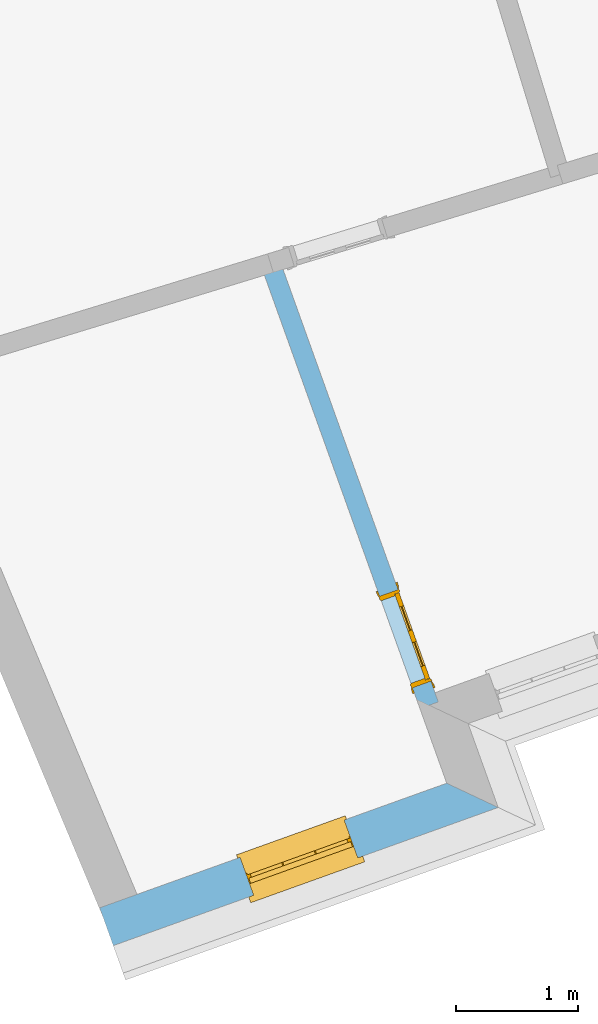
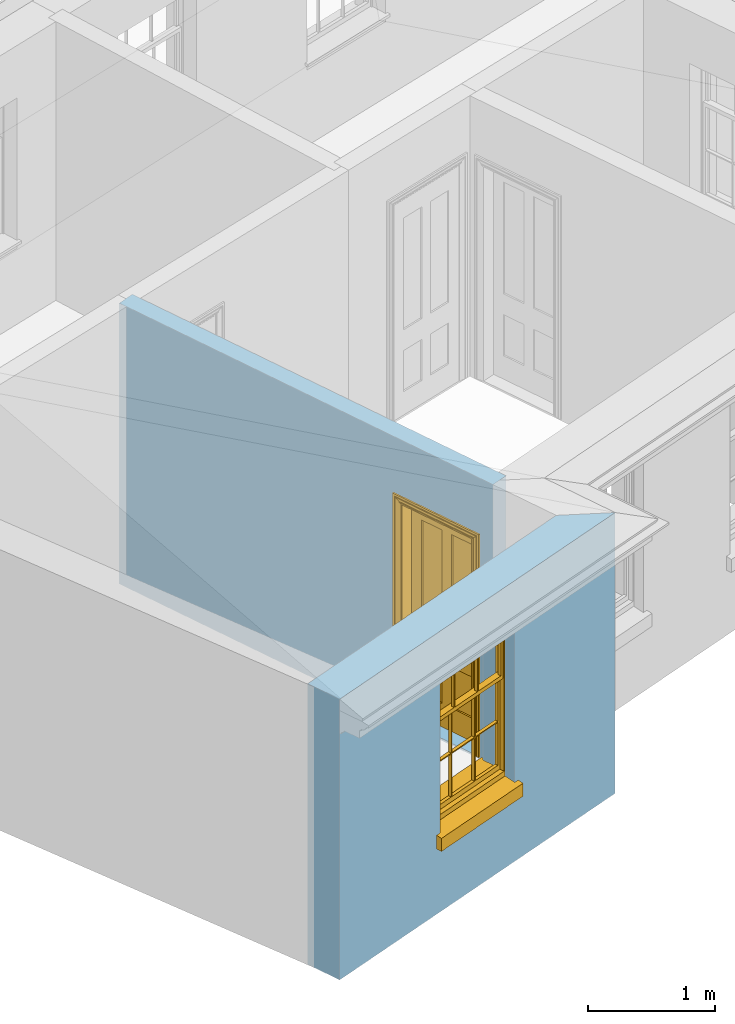
# One storey, part 2 of 10: 1 door, 1 window, 2 openings, plus 2 elements that do not belong to this part.
"""IFC2X3 building model written with IfcOpenShell, lengths in metres."""

from ifc_helpers import new_model, si_unit, frame, origin, place, context, subcontext, project, spatial, polyline, outline, extrude, faceted_brep, material, layer, layer_set, layer_usage, element, fill, save


model = new_model("IFC2X3")

# Units and contexts
model_context = context("Model", 3, world=origin())
body_context = subcontext(model_context, "Body", "Model", "MODEL_VIEW")
ifc_project = project(units=[si_unit("PLANEANGLEUNIT", "RADIAN"), si_unit("MASSUNIT", "GRAM", prefix="KILO"), si_unit("FORCEUNIT", "NEWTON", prefix="KILO"), si_unit("LENGTHUNIT", "METRE")], contexts=[model_context])

# Site, building, storey
site_placement = place(None, origin())
site = spatial("IfcSite", under=ifc_project, at=site_placement, CompositionType="ELEMENT")
building_placement = place(None, origin())
building = spatial("IfcBuilding", under=site, at=building_placement, Name="Building plot-9", CompositionType="ELEMENT")
storey_placement = place(None, frame((0.0, 0.0, 4.3)))
storey = spatial("IfcBuildingStorey", under=building, at=storey_placement, Name="Floor 1", CompositionType="ELEMENT", Elevation=4.3)

# Wall, opening, window
ifc_material_1 = material(Name="Masonry")
ifc_layer_1 = layer(ifc_material_1, 0.33, ventilated=False)
ifc_layer_set_1 = layer_set([ifc_layer_1], Name="My Wall")
ifc_layer_usage_1 = layer_usage(ifc_layer_set_1, "AXIS2", "NEGATIVE", 0.08)
wall_1_placement = place(storey_placement, origin())
wall_1 = element("IfcWallStandardCase", 1, at=wall_1_placement, inside=storey, material=ifc_layer_usage_1, Name="exterior", context=body_context, shape_type="SweptSolid", body=[
    extrude(outline(polyline([(31.1651656744123, 12.8391071130311), (31.2766588517913, 12.5285120850639), (34.4384860645198, 13.6635018000555), (34.0163978591737, 13.8626036506437), (31.1651656744123, 12.8391071130311)])), origin(), (0.0, 0.0, 1.0), 2.7),
])
opening_1_placement = place(storey_placement, frame((0.0, 0.0, 0.75)))
opening_1 = element("IfcOpeningElement", 2, at=opening_1_placement, cuts=wall_1, Name="Opening", ObjectType="Opening", context=body_context, shape_type="SweptSolid", body=[
    extrude(outline(polyline([(32.4293277983826, 12.9422815010221), (33.2858171179285, 13.2497323840973), (33.1743239405496, 13.5603274120645), (32.3178346210036, 13.2528765289893), (32.4293277983826, 12.9422815010221)])), origin(), (0.0, 0.0, 1.0), 1.445),
])
window_placement = place(storey_placement, frame((32.3448632700652, 13.1775807646336, 0.75), z_axis=(0.0, 0.0, 1.0), x_axis=(0.856489319545936, 0.30745088307525, 0.0)))
window = element("IfcWindow", 3, at=window_placement, inside=storey, Name="bedroom outside window", OverallHeight=1.445, OverallWidth=0.91, context=body_context, shape_type="Brep", held_by="IfcProductRepresentation", body=[
    faceted_brep([(0.876875, -0.105, 0.999097), (0.876875, -0.105, 1.411875), (0.9, -0.105, 1.435), (0.033125, -0.105, 1.411875), (0.033125, -0.105, 0.999097), (0.01, -0.105, 1.435), (0.033125, -0.135, 1.411875), (0.01, -0.135, 1.435), (0.033125, -0.135, 0.999097), (0.876875, -0.135, 1.411875), (0.876875, -0.135, 0.999097), (0.9, -0.135, 1.435), (0.033125, -0.105, 0.960972), (0.01, -0.105, 0.960972), (0.033125, -0.105, 0.548195), (0.876875, -0.105, 0.960972), (0.876875, -0.105, 0.548195), (0.9, -0.105, 0.960972), (0.876875, -0.105, 0.538195), (0.876875, -0.105, 0.125417), (0.9, -0.105, 0.077167), (0.033125, -0.105, 0.125417), (0.033125, -0.105, 0.538195), (0.01, -0.105, 0.077167), (0.9, -0.135, 0.960972), (0.01, -0.135, 0.960972), (-0.0425, -0.25, 0.01), (-0.0425, -0.3, 0.001667), (0.0, -0.25, 0.01), (0.9525, -0.25, 0.01), (0.91, -0.25, 0.01), (0.9525, -0.3, 0.001667), (-0.02, 0.08, 0.077167), (0.0, 0.08, 0.077167), (-0.02, 0.11, 0.077167), (0.0, -0.06, 0.077167), (0.01, -0.06, 0.077167), (0.91, -0.06, 0.077167), (0.91, 0.08, 0.077167), (0.9, -0.06, 0.077167), (0.93, 0.08, 0.077167), (0.93, 0.11, 0.077167), (0.01, -0.105, 0.999097), (0.01, -0.075, 0.999097), (0.9, -0.105, 0.999097), (0.9, -0.075, 0.999097), (0.876875, -0.075, 0.125417), (0.876875, -0.075, 0.538195), (0.9, -0.075, 0.077167), (0.876875, -0.075, 0.548195), (0.876875, -0.075, 0.960972), (0.033125, -0.075, 0.125417), (0.01, -0.075, 0.077167), (0.033125, -0.075, 0.538195), (0.033125, -0.075, 0.960972), (0.033125, -0.075, 0.548195), (-0.02, 0.08, 0.052167), (-0.02, 0.11, 0.052167), (0.93, 0.11, 0.052167), (0.93, 0.08, 0.052167), (0.91, 0.08, 0.052167), (0.0, 0.08, 0.052167), (0.91, -0.15, 0.026667), (0.0, -0.15, 0.026667), (-0.0425, -0.3, -0.123333), (0.9525, -0.3, -0.123333), (-0.0425, -0.25, -0.123333), (0.9525, -0.25, -0.123333), (0.01, -0.06, 1.435), (0.9, -0.06, 1.435), (0.0, -0.06, 1.445), (0.91, -0.06, 1.445), (0.01, -0.15, 0.077167), (0.9, -0.15, 0.077167), (0.592292, -0.105, 0.125417), (0.592292, -0.075, 0.125417), (0.317708, -0.075, 0.125417), (0.317708, -0.105, 0.125417), (0.592292, -0.105, 0.548195), (0.317708, -0.105, 0.548195), (0.317708, -0.105, 0.538195), (0.592292, -0.105, 0.538195), (0.592292, -0.075, 0.548195), (0.317708, -0.075, 0.548195), (0.602292, -0.075, 0.548195), (0.602292, -0.105, 0.548195), (0.317708, -0.075, 0.538195), (0.307708, -0.075, 0.125417), (0.307708, -0.075, 0.538195), (0.602292, -0.075, 0.538195), (0.602292, -0.075, 0.125417), (0.592292, -0.075, 0.538195), (0.307708, -0.075, 0.548195), (0.317708, -0.075, 0.960972), (0.307708, -0.075, 0.960972), (0.602292, -0.075, 0.960972), (0.592292, -0.075, 0.960972), (0.307708, -0.105, 0.538195), (0.307708, -0.105, 0.125417), (0.307708, -0.105, 0.548195), (0.307708, -0.105, 0.960972), (0.592292, -0.105, 0.960972), (0.317708, -0.105, 0.960972), (0.602292, -0.105, 0.960972), (0.602292, -0.105, 0.538195), (0.602292, -0.105, 0.125417), (0.317708, -0.135, 1.411875), (0.307708, -0.135, 1.411875), (0.307708, -0.135, 0.999097), (0.317708, -0.135, 0.999097), (0.602292, -0.135, 1.411875), (0.592292, -0.135, 1.411875), (0.592292, -0.135, 0.999097), (0.602292, -0.135, 0.999097), (0.317708, -0.105, 0.999097), (0.307708, -0.105, 0.999097), (0.307708, -0.105, 1.411875), (0.317708, -0.105, 1.411875), (0.602292, -0.105, 0.999097), (0.592292, -0.105, 0.999097), (0.592292, -0.105, 1.411875), (0.602292, -0.105, 1.411875), (0.91, -0.15, 1.445), (0.9, -0.15, 1.435), (0.01, -0.15, 1.435), (0.0, -0.15, 1.445), (0.91, -0.25, 0.0), (0.0, -0.25, 0.0), (0.91, 0.08, 0.0), (0.0, 0.08, 0.0)], [[[0, 1, 2]], [[3, 4, 5]], [[6, 7, 8]], [[9, 10, 11]], [[12, 13, 14]], [[15, 16, 17]], [[18, 19, 20]], [[21, 22, 23]], [[24, 15, 17]], [[13, 12, 25]], [[26, 27, 28]], [[29, 30, 31]], [[32, 33, 34]], [[35, 36, 33]], [[37, 38, 39]], [[40, 41, 38]], [[42, 4, 43]], [[44, 45, 0]], [[46, 47, 48]], [[49, 50, 45]], [[51, 52, 53]], [[54, 55, 43]], [[38, 33, 36, 39]], [[41, 34, 33, 38]], [[56, 32, 34, 57]], [[57, 34, 41, 58]], [[58, 41, 40, 59]], [[57, 58, 60, 61]], [[52, 48, 39, 36]], [[62, 63, 28, 30]], [[27, 31, 30, 28]], [[27, 64, 65, 31]], [[66, 67, 65, 64]], [[2, 5, 68, 69]], [[68, 70, 71, 69]], [[20, 23, 72, 73]], [[73, 72, 63, 62]], [[74, 75, 76, 77]], [[78, 79, 80, 81]], [[78, 82, 83, 79]], [[16, 49, 84, 85]], [[86, 76, 87, 88]], [[89, 90, 75, 91]], [[92, 88, 53, 55]], [[82, 91, 86, 83]], [[93, 83, 92, 94]], [[95, 84, 82, 96]], [[89, 84, 49, 47]], [[97, 88, 87, 98]], [[22, 53, 88, 97]], [[81, 91, 75, 74]], [[80, 86, 91, 81]], [[77, 76, 86, 80]], [[99, 92, 55, 14]], [[100, 94, 92, 99]], [[101, 96, 82, 78]], [[79, 83, 93, 102]], [[85, 84, 95, 103]], [[104, 89, 47, 18]], [[105, 90, 89, 104]], [[104, 18, 16, 85]], [[80, 97, 98, 77]], [[104, 81, 74, 105]], [[103, 101, 78, 85]], [[99, 14, 22, 97]], [[102, 100, 99, 79]], [[106, 107, 108, 109]], [[110, 111, 112, 113]], [[114, 115, 116, 117]], [[118, 119, 120, 121]], [[107, 116, 115, 108]], [[111, 120, 119, 112]], [[109, 114, 117, 106]], [[113, 118, 121, 110]], [[85, 78, 81, 104]], [[84, 89, 91, 82]], [[83, 86, 88, 92]], [[79, 99, 97, 80]], [[109, 112, 119, 114]], [[102, 93, 96, 101]], [[106, 117, 120, 111]], [[98, 87, 51, 21]], [[6, 3, 116, 107]], [[110, 121, 1, 9]], [[19, 46, 90, 105]], [[26, 66, 64, 27]], [[29, 31, 65, 67]], [[25, 24, 112, 109]], [[11, 7, 106, 111]], [[75, 48, 52, 76]], [[43, 45, 96, 93]], [[45, 43, 114, 119]], [[5, 2, 120, 117]], [[24, 25, 102, 101]], [[42, 5, 4]], [[2, 44, 0]], [[49, 45, 48, 47]], [[52, 43, 55, 53]], [[14, 13, 23, 22]], [[20, 17, 16, 18]], [[24, 11, 10]], [[25, 8, 7]], [[8, 4, 3, 6]], [[9, 1, 0, 10]], [[15, 50, 49, 16]], [[18, 47, 46, 19]], [[21, 51, 53, 22]], [[14, 55, 54, 12]], [[44, 2, 69, 45]], [[68, 5, 42, 43]], [[36, 35, 70, 68]], [[39, 69, 71, 37]], [[62, 122, 123, 73]], [[63, 72, 124, 125]], [[8, 108, 115, 4]], [[113, 10, 0, 118]], [[94, 100, 12, 54]], [[17, 20, 73, 24]], [[72, 23, 13, 25]], [[52, 36, 68, 43]], [[69, 39, 48, 45]], [[11, 24, 73, 123]], [[7, 124, 72, 25]], [[23, 77, 98]], [[98, 21, 23]], [[105, 74, 20]], [[20, 19, 105]], [[20, 74, 77, 23]], [[113, 112, 24]], [[24, 10, 113]], [[25, 109, 108]], [[108, 8, 25]], [[110, 9, 11]], [[11, 111, 110]], [[7, 6, 107]], [[107, 106, 7]], [[5, 117, 116]], [[116, 3, 5]], [[121, 120, 2]], [[2, 1, 121]], [[11, 123, 124, 7]], [[122, 125, 124, 123]], [[43, 93, 94]], [[94, 54, 43]], [[96, 45, 95]], [[50, 95, 45]], [[15, 103, 95, 50]], [[48, 75, 90]], [[90, 46, 48]], [[87, 76, 52]], [[52, 51, 87]], [[103, 15, 24]], [[24, 101, 103]], [[100, 102, 25]], [[25, 12, 100]], [[115, 114, 43]], [[43, 4, 115]], [[118, 0, 45]], [[45, 119, 118]], [[71, 70, 125, 122]], [[70, 35, 63, 125]], [[122, 62, 37, 71]], [[126, 67, 66, 127]], [[60, 58, 59]], [[38, 60, 59, 40]], [[61, 56, 57]], [[32, 56, 61, 33]], [[61, 60, 128, 129]], [[62, 60, 38, 37]], [[126, 128, 60, 62]], [[33, 61, 63, 35]], [[61, 129, 127, 63]], [[128, 126, 127, 129]], [[28, 127, 66, 26]], [[63, 127, 28]], [[29, 67, 126, 30]], [[30, 126, 62]]]),
])
fill(opening_1, window)

# Wall, opening, door
ifc_material_2 = material(Name="Masonry")
ifc_layer_2 = layer(ifc_material_2, 0.16, ventilated=False)
ifc_layer_set_2 = layer_set([ifc_layer_2], Name="My Wall")
ifc_layer_usage_2 = layer_usage(ifc_layer_set_2, "AXIS2", "NEGATIVE", 0.08)
wall_2_placement = place(storey_placement, origin())
wall_2 = element("IfcWallStandardCase", 4, at=wall_2_placement, inside=storey, material=ifc_layer_usage_2, Name="interior", context=body_context, shape_type="SweptSolid", body=[
    extrude(outline(polyline([(32.6432213305608, 18.1615375726665), (32.4926298018494, 18.1074802745433), (33.7960197636379, 14.4765276803952), (33.9466112923493, 14.5305849785184), (32.6432213305608, 18.1615375726665)])), origin(), (0.0, 0.0, 1.0), 2.7),
])
opening_2_placement = place(storey_placement, frame((0.0, 0.0, 0.0199999999999996)))
opening_2 = element("IfcOpeningElement", 5, at=opening_2_placement, cuts=wall_2, Name="Opening", ObjectType="Opening", context=body_context, shape_type="SweptSolid", body=[
    extrude(outline(polyline([(33.4649188126338, 15.3989007937524), (33.7352053032494, 14.6459431501955), (33.8857968319608, 14.7000004483187), (33.6155103413452, 15.4529580918755), (33.4649188126338, 15.3989007937524)])), origin(), (0.0, 0.0, 1.0), 2.1),
])
door_placement = place(storey_placement, frame((33.5402145769895, 15.425929442814, 0.0199999999999996), z_axis=(0.0, 0.0, 1.0), x_axis=(0.270286490615611, -0.75295764355686, 0.0)))
door = element("IfcDoor", 6, at=door_placement, inside=storey, Name="bedroom inside door", OverallHeight=2.1, OverallWidth=0.8, context=body_context, shape_type="Brep", held_by="IfcProductRepresentation", body=[
    faceted_brep([(0.773, 0.08, 1.895), (0.66, 0.08, 1.895), (0.66, 0.08, 2.073), (0.773, 0.08, 2.073), (0.773, 0.08, 0.82), (0.66, 0.08, 0.82), (0.45, 0.08, 1.895), (0.45, 0.08, 2.073), (0.773, 0.08, 0.62), (0.66, 0.08, 0.62), (0.66, 0.065, 0.82), (0.66, 0.065, 1.895), (0.45, 0.065, 1.895), (0.35, 0.08, 1.895), (0.35, 0.08, 2.073), (0.773, 0.08, 0.225), (0.66, 0.08, 0.225), (0.45, 0.08, 0.62), (0.45, 0.08, 0.82), (0.45, 0.065, 0.82), (0.35, 0.08, 0.82), (0.14, 0.08, 2.073), (0.14, 0.08, 1.895), (0.773, 0.08, 0.0), (0.66, 0.08, 0.0), (0.66, 0.065, 0.225), (0.66, 0.065, 0.62), (0.45, 0.065, 0.62), (0.35, 0.08, 0.62), (0.35, 0.065, 0.82), (0.35, 0.065, 1.895), (0.14, 0.065, 1.895), (0.027, 0.08, 2.073), (0.027, 0.08, 1.895), (0.773, 0.042, 0.0), (0.66, 0.042, 0.0), (0.45, 0.08, 0.0), (0.45, 0.08, 0.225), (0.45, 0.065, 0.225), (0.35, 0.08, 0.225), (0.14, 0.08, 0.82), (0.14, 0.08, 0.62), (0.14, 0.065, 0.82), (0.027, 0.08, 0.82), (0.773, 0.042, 0.225), (0.66, 0.042, 0.225), (0.45, 0.042, 0.0), (0.35, 0.08, 0.0), (0.35, 0.065, 0.225), (0.35, 0.065, 0.62), (0.14, 0.065, 0.62), (0.027, 0.08, 0.62), (0.773, 0.042, 0.62), (0.66, 0.042, 0.62), (0.45, 0.042, 0.225), (0.35, 0.042, 0.0), (0.14, 0.08, 0.225), (0.14, 0.08, 0.0), (0.14, 0.065, 0.225), (0.027, 0.08, 0.225), (0.773, 0.042, 0.82), (0.66, 0.042, 0.82), (0.66, 0.057, 0.62), (0.66, 0.057, 0.225), (0.45, 0.057, 0.225), (0.35, 0.042, 0.225), (0.14, 0.042, 0.0), (0.027, 0.08, 0.0), (0.773, 0.042, 1.895), (0.66, 0.042, 1.895), (0.45, 0.042, 0.62), (0.45, 0.042, 0.82), (0.45, 0.057, 0.62), (0.35, 0.042, 0.62), (0.14, 0.042, 0.225), (0.027, 0.042, 0.0), (0.773, 0.042, 2.073), (0.66, 0.042, 2.073), (0.66, 0.057, 1.895), (0.66, 0.057, 0.82), (0.45, 0.057, 0.82), (0.35, 0.042, 0.82), (0.35, 0.057, 0.62), (0.35, 0.057, 0.225), (0.14, 0.057, 0.225), (0.027, 0.042, 0.225), (0.45, 0.042, 1.895), (0.45, 0.042, 2.073), (0.45, 0.057, 1.895), (0.35, 0.042, 1.895), (0.14, 0.042, 0.82), (0.14, 0.042, 0.62), (0.14, 0.057, 0.62), (0.027, 0.042, 0.62), (0.35, 0.042, 2.073), (0.35, 0.057, 1.895), (0.35, 0.057, 0.82), (0.14, 0.057, 0.82), (0.027, 0.042, 0.82), (0.14, 0.042, 2.073), (0.14, 0.042, 1.895), (0.14, 0.057, 1.895), (0.027, 0.042, 1.895), (0.027, 0.042, 2.073), (0.02, 0.085, 0.0), (0.005, 0.09, 0.0), (0.005, 0.09, 2.095), (0.02, 0.085, 2.08), (0.02, 0.08, 0.0), (0.0, 0.085, 0.0), (0.0, 0.085, 2.1), (0.795, 0.09, 2.095), (0.78, 0.085, 2.08), (0.02, 0.08, 2.08), (0.0, 0.08, 0.0), (-0.032, 0.095, 0.0), (-0.032, 0.095, 2.132), (0.8, 0.085, 2.1), (0.795, 0.09, 0.0), (0.78, 0.085, 0.0), (0.78, 0.08, 2.08), (0.04, 0.04, 0.0), (0.025, 0.04, 0.0), (0.025, 0.04, 2.075), (0.04, 0.04, 2.06), (-0.04, 0.09, 0.0), (-0.04, 0.09, 2.14), (0.832, 0.095, 2.132), (0.8, 0.085, 0.0), (0.78, 0.08, 0.0), (0.8, 0.08, 0.0), (0.86, 0.08, 0.0), (0.86, 0.08, 2.16), (0.8, 0.08, 2.1), (-0.06, 0.08, 2.16), (0.0, 0.08, 2.1), (-0.06, 0.08, 0.0), (-0.04, 0.095, 0.0), (-0.04, 0.095, 2.14), (0.84, 0.09, 2.14), (0.832, 0.095, 0.0), (0.84, 0.09, 0.0), (0.86, 0.095, 0.0), (0.86, 0.095, 2.16), (-0.06, 0.095, 2.16), (-0.06, 0.095, 0.0), (0.84, 0.095, 0.0), (0.84, 0.095, 2.14), (-0.025, -0.095, 0.0), (-0.025, -0.09, 0.0), (-0.025, -0.09, 2.125), (-0.025, -0.095, 2.125), (-0.017, -0.095, 0.0), (-0.017, -0.095, 2.117), (0.825, -0.09, 2.125), (0.825, -0.095, 2.125), (0.825, -0.095, 0.0), (0.845, -0.095, 0.0), (-0.045, -0.095, 2.145), (-0.045, -0.095, 0.0), (0.845, -0.095, 2.145), (0.015, -0.085, 0.0), (0.015, -0.085, 2.085), (0.817, -0.095, 2.117), (0.825, -0.09, 0.0), (0.845, -0.08, 0.0), (0.845, -0.08, 2.145), (-0.045, -0.08, 2.145), (-0.045, -0.08, 0.0), (0.02, -0.09, 0.0), (0.02, -0.09, 2.08), (0.785, -0.085, 2.085), (0.817, -0.095, 0.0), (0.8, -0.08, 0.0), (0.8, -0.08, 2.1), (0.0, -0.08, 2.1), (0.0, -0.08, 0.0), (0.035, -0.085, 0.0), (0.035, -0.085, 2.065), (0.78, -0.09, 2.08), (0.785, -0.085, 0.0), (0.775, 0.04, 2.075), (0.76, 0.04, 2.06), (0.035, -0.08, 2.065), (0.035, -0.08, 0.0), (0.765, -0.085, 2.065), (0.78, -0.09, 0.0), (0.765, -0.08, 0.0), (0.765, -0.08, 2.065), (0.765, -0.085, 0.0), (0.04, -0.08, 2.06), (0.04, -0.08, 0.0), (0.76, -0.08, 2.06), (0.76, -0.08, 0.0), (0.76, 0.04, 0.0), (0.775, 0.04, 0.0), (0.025, 0.08, 0.0), (0.025, 0.08, 2.075), (0.775, 0.08, 0.0), (0.775, 0.08, 2.075)], [[[0, 1, 2, 3]], [[1, 0, 4, 5]], [[1, 6, 7, 2]], [[8, 9, 5, 4]], [[1, 5, 10, 11]], [[6, 1, 11, 12]], [[6, 13, 14, 7]], [[15, 16, 9, 8]], [[9, 17, 18, 5]], [[5, 18, 19, 10]], [[10, 19, 12, 11]], [[18, 6, 12, 19]], [[18, 20, 13, 6]], [[21, 14, 13, 22]], [[23, 24, 16, 15]], [[9, 16, 25, 26]], [[17, 9, 26, 27]], [[17, 28, 20, 18]], [[13, 20, 29, 30]], [[22, 13, 30, 31]], [[32, 21, 22, 33]], [[34, 35, 24, 23]], [[24, 36, 37, 16]], [[16, 37, 38, 25]], [[25, 38, 27, 26]], [[37, 17, 27, 38]], [[37, 39, 28, 17]], [[40, 20, 28, 41]], [[20, 40, 42, 29]], [[31, 30, 29, 42]], [[40, 22, 31, 42]], [[33, 22, 40, 43]], [[35, 34, 44, 45]], [[35, 46, 36, 24]], [[36, 47, 39, 37]], [[28, 39, 48, 49]], [[41, 28, 49, 50]], [[43, 40, 41, 51]], [[45, 44, 52, 53]], [[46, 35, 45, 54]], [[46, 55, 47, 36]], [[56, 39, 47, 57]], [[39, 56, 58, 48]], [[50, 49, 48, 58]], [[56, 41, 50, 58]], [[51, 41, 56, 59]], [[53, 52, 60, 61]], [[45, 53, 62, 63]], [[54, 45, 63, 64]], [[55, 46, 54, 65]], [[55, 66, 57, 47]], [[59, 56, 57, 67]], [[61, 60, 68, 69]], [[70, 53, 61, 71]], [[53, 70, 72, 62]], [[72, 64, 63, 62]], [[70, 54, 64, 72]], [[65, 54, 70, 73]], [[65, 74, 66, 55]], [[67, 57, 66, 75]], [[69, 68, 76, 77]], [[61, 69, 78, 79]], [[71, 61, 79, 80]], [[73, 70, 71, 81]], [[65, 73, 82, 83]], [[74, 65, 83, 84]], [[74, 85, 75, 66]], [[86, 69, 77, 87]], [[69, 86, 88, 78]], [[88, 80, 79, 78]], [[86, 71, 80, 88]], [[81, 71, 86, 89]], [[73, 81, 90, 91]], [[73, 91, 92, 82]], [[83, 82, 92, 84]], [[91, 74, 84, 92]], [[91, 93, 85, 74]], [[89, 86, 87, 94]], [[81, 89, 95, 96]], [[90, 81, 96, 97]], [[90, 98, 93, 91]], [[94, 99, 100, 89]], [[89, 100, 101, 95]], [[101, 97, 96, 95]], [[100, 90, 97, 101]], [[100, 102, 98, 90]], [[99, 103, 102, 100]], [[32, 103, 99, 21]], [[102, 103, 32, 33]], [[98, 102, 33, 43]], [[21, 99, 94, 14]], [[94, 87, 7, 14]], [[7, 87, 77, 2]], [[76, 3, 2, 77]], [[43, 51, 93, 98]], [[51, 59, 85, 93]], [[67, 75, 85, 59]], [[34, 23, 15, 44]], [[44, 15, 8, 52]], [[52, 8, 4, 60]], [[0, 68, 60, 4]], [[0, 3, 76, 68]], [[104, 105, 106, 107]], [[104, 108, 109, 105]], [[105, 109, 110, 106]], [[107, 106, 111, 112]], [[107, 113, 108, 104]], [[114, 109, 108]], [[109, 115, 116, 110]], [[106, 110, 117, 111]], [[112, 111, 118, 119]], [[113, 107, 112, 120]], [[121, 122, 123, 124]], [[115, 109, 114, 125]], [[115, 125, 126, 116]], [[110, 116, 127, 117]], [[111, 117, 128, 118]], [[118, 128, 129, 119]], [[120, 112, 119, 129]], [[130, 129, 128]], [[130, 131, 132, 133]], [[133, 132, 134, 135]], [[135, 134, 136, 114]], [[136, 125, 114]], [[125, 137, 138, 126]], [[116, 126, 139, 127]], [[117, 127, 140, 128]], [[141, 130, 128, 140]], [[131, 130, 141]], [[131, 142, 143, 132]], [[132, 143, 144, 134]], [[134, 144, 145, 136]], [[137, 125, 136, 145]], [[143, 142, 146]], [[143, 146, 147]], [[137, 145, 144]], [[143, 147, 138]], [[138, 137, 144]], [[143, 138, 144]], [[126, 138, 147, 139]], [[127, 139, 141, 140]], [[142, 131, 141, 146]], [[139, 147, 146, 141]], [[148, 149, 150, 151]], [[149, 152, 153, 150]], [[151, 150, 154, 155]], [[155, 156, 157]], [[158, 159, 148]], [[158, 148, 151]], [[155, 157, 160]], [[158, 151, 155]], [[155, 160, 158]], [[152, 161, 162, 153]], [[150, 153, 163, 154]], [[155, 154, 164, 156]], [[156, 164, 165, 157]], [[157, 165, 166, 160]], [[160, 166, 167, 158]], [[158, 167, 168, 159]], [[161, 169, 170, 162]], [[153, 162, 171, 163]], [[154, 163, 172, 164]], [[165, 164, 173]], [[165, 173, 174, 166]], [[166, 174, 175, 167]], [[167, 175, 176, 168]], [[169, 177, 178, 170]], [[162, 170, 179, 171]], [[163, 171, 180, 172]], [[172, 180, 173, 164]], [[124, 123, 181, 182]], [[183, 178, 177, 184]], [[170, 178, 185, 179]], [[171, 179, 186, 180]], [[187, 173, 180]], [[185, 188, 187, 189]], [[188, 185, 178, 183]], [[179, 185, 189, 186]], [[189, 187, 180, 186]], [[190, 183, 184, 191]], [[192, 188, 183, 190]], [[191, 184, 122, 121]], [[124, 190, 191, 121]], [[193, 187, 188, 192]], [[182, 192, 190, 124]], [[184, 176, 122]], [[194, 195, 187, 193]], [[192, 182, 194, 193]], [[161, 176, 184]], [[114, 108, 122, 176]], [[173, 187, 195]], [[152, 149, 176, 161]], [[169, 161, 184, 177]], [[196, 122, 108]], [[176, 175, 135, 114]], [[173, 195, 129, 130]], [[176, 149, 168]], [[123, 122, 196, 197]], [[196, 108, 113, 197]], [[175, 174, 133, 135]], [[198, 129, 195]], [[133, 174, 173, 130]], [[159, 168, 149, 148]], [[181, 123, 197, 199]], [[197, 113, 120, 199]], [[199, 120, 129, 198]], [[195, 181, 199, 198]], [[195, 194, 182, 181]]]),
])
fill(opening_2, door)

save(model, "model.ifc")
